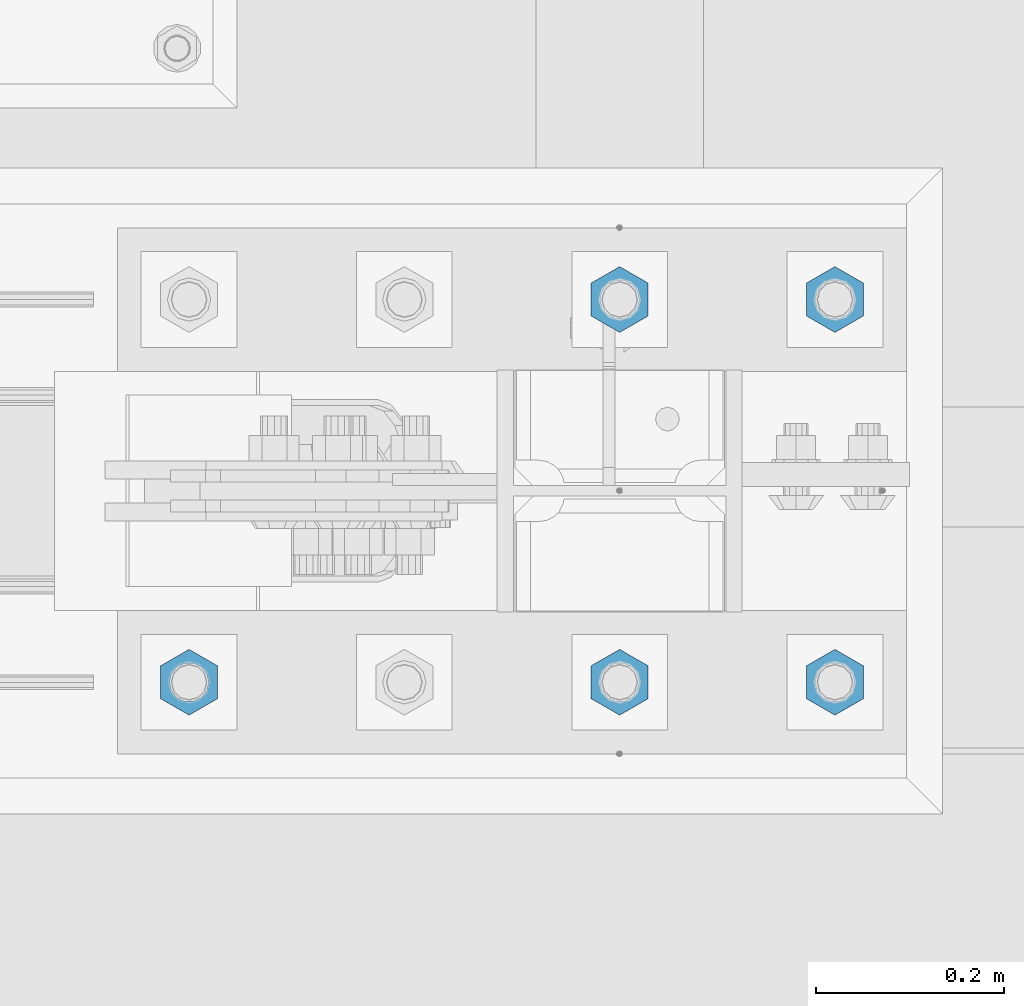
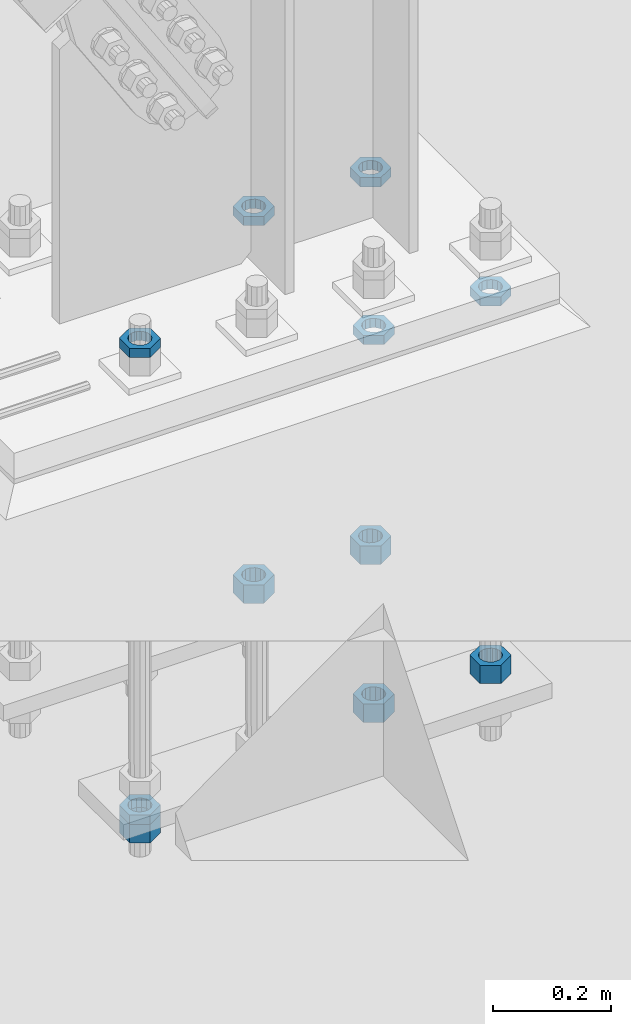
# One storey, part 2870 of 3843: 11 beams, 1 element without a shape of its own.
"""IFC2X3 building model written with IfcOpenShell, lengths in millimetres."""

from ifc_helpers import new_model, si_unit, frame, origin_with_axes, place, context, subcontext, project, spatial, faceted_brep, material, type_object, element, aggregate, save


model = new_model("IFC2X3")

# Units and contexts
model_context = context("Model", 3, precision=1e-05, world=origin_with_axes())
body_context = subcontext(model_context, "Body", "Model", "MODEL_VIEW")
ifc_project = project(units=[si_unit("LENGTHUNIT", "METRE", prefix="MILLI"), si_unit("AREAUNIT", "SQUARE_METRE"), si_unit("VOLUMEUNIT", "CUBIC_METRE"), si_unit("MASSUNIT", "GRAM", prefix="KILO"), si_unit("TIMEUNIT", "SECOND"), si_unit("PLANEANGLEUNIT", "RADIAN"), si_unit("SOLIDANGLEUNIT", "STERADIAN"), si_unit("THERMODYNAMICTEMPERATUREUNIT", "DEGREE_CELSIUS"), si_unit("LUMINOUSINTENSITYUNIT", "LUMEN")], contexts=[model_context])

# Site, building, storey
site_placement = place(None, origin_with_axes())
site = spatial("IfcSite", under=ifc_project, at=site_placement, CompositionType="ELEMENT")
building_placement = place(site_placement, origin_with_axes())
building = spatial("IfcBuilding", under=site, at=building_placement, Name="Undefined", CompositionType="ELEMENT")
storey_placement = place(building_placement, origin_with_axes())
storey = spatial("IfcBuildingStorey", under=building, at=storey_placement, Name="Undefined", CompositionType="ELEMENT", Elevation=0.0)

# Assembly, beams
assembly_placement = place(storey_placement, origin_with_axes())
assembly = element("IfcElementAssembly", 1, at=assembly_placement, inside=storey, Name="TEMPLATE", AssemblyPlace="NOTDEFINED", PredefinedType="RIGID_FRAME")
ifc_material = material(Name="STEEL/A572-50")
beam_type_1 = type_object("IfcBeamType", Name="1-1/2_HEAVY_HEX_NUT", PredefinedType="NOTDEFINED")
beam_1_placement = place(assembly_placement, frame((30708.6000195326, 88912.7, 29298.9), z_axis=(1.0, 0.0, 0.0), x_axis=(0.0, 0.0, -1.0)))
beam_1 = element("IfcBeam", 2, at=beam_1_placement, type_object=beam_type_1, material=ifc_material, Name="NUT", ObjectType="1-1/2_HEAVY_HEX_NUT", context=body_context, shape_type="Brep", body=[
    faceted_brep([(0.0, -34.9199981689453, 0.0), (0.0, -17.4599990844727, -30.25), (38.0999999999985, -17.4599990844727, -30.25), (38.0999999999985, -34.9199981689453, 0.0), (0.0, 17.4599990844727, -30.25), (38.0999999999985, 17.4599990844727, -30.25), (0.0, 34.9199981689453, 0.0), (38.0999999999985, 34.9199981689453, 0.0), (0.0, 17.4599990844727, 30.25), (38.0999999999985, 17.4599990844727, 30.25), (0.0, -17.4599990844727, 30.25), (38.0999999999985, -17.4599990844727, 30.25), (0.0, 0.0, 20.6399993896484), (0.0, 8.9553601105581, 18.5959968835959), (38.0999999999985, 8.9553601105581, 18.5959968835959), (38.0999999999985, 0.0, 20.6399993896484), (0.0, 16.1370013209525, 12.8688291298167), (38.0999999999985, 16.1370013209525, 12.8688291298167), (0.0, 20.1225115123816, 4.59283194104501), (38.0999999999985, 20.1225115123816, 4.59283194104501), (0.0, 20.1225115123816, -4.59283194104501), (38.0999999999985, 20.1225115123816, -4.59283194104501), (0.0, 16.1370013209525, -12.8688291298167), (38.0999999999985, 16.1370013209525, -12.8688291298167), (0.0, 8.9553601105581, -18.5959968835959), (38.0999999999985, 8.9553601105581, -18.5959968835959), (0.0, 0.0, -20.6399993896484), (38.0999999999985, 0.0, -20.6399993896484), (0.0, -8.9553601105581, -18.5959968835959), (38.0999999999985, -8.9553601105581, -18.5959968835959), (0.0, -16.1370013209525, -12.8688291298167), (38.0999999999985, -16.1370013209525, -12.8688291298167), (0.0, -20.1225115123816, -4.59283194104501), (38.0999999999985, -20.1225115123816, -4.59283194104501), (0.0, -20.1225115123816, 4.59283194104501), (38.0999999999985, -20.1225115123816, 4.59283194104501), (0.0, -16.1370013209525, 12.8688291298167), (38.0999999999985, -16.1370013209525, 12.8688291298167), (0.0, -8.9553601105581, 18.5959968835959), (38.0999999999985, -8.9553601105581, 18.5959968835959)], [[[0, 1, 2, 3]], [[1, 4, 5, 2]], [[4, 6, 7, 5]], [[6, 8, 9, 7]], [[8, 10, 11, 9]], [[10, 0, 3, 11]], [[12, 13, 14, 15]], [[13, 16, 17, 14]], [[16, 18, 19, 17]], [[18, 20, 21, 19]], [[20, 22, 23, 21]], [[22, 24, 25, 23]], [[24, 26, 27, 25]], [[26, 28, 29, 27]], [[28, 30, 31, 29]], [[30, 32, 33, 31]], [[32, 34, 35, 33]], [[34, 36, 37, 35]], [[36, 38, 39, 37]], [[38, 12, 15, 39]], [[5, 7, 9, 11, 3, 2], [17, 19, 21, 23, 25, 27, 29, 31, 33, 35, 37, 39, 15, 14]], [[10, 8, 6, 4, 1, 0], [38, 36, 34, 32, 30, 28, 26, 24, 22, 20, 18, 16, 13, 12]]]),
])
beam_2_placement = place(assembly_placement, frame((30480.0000195326, 88912.7, 29298.9), z_axis=(1.0, 0.0, 0.0), x_axis=(0.0, 0.0, -1.0)))
beam_2 = element("IfcBeam", 3, at=beam_2_placement, type_object=beam_type_1, material=ifc_material, Name="NUT", ObjectType="1-1/2_HEAVY_HEX_NUT", context=body_context, shape_type="Brep", body=[
    faceted_brep([(0.0, -34.9199981689453, 0.0), (0.0, -17.4599990844727, -30.25), (38.0999999999985, -17.4599990844727, -30.25), (38.0999999999985, -34.9199981689453, 0.0), (0.0, 17.4599990844727, -30.25), (38.0999999999985, 17.4599990844727, -30.25), (0.0, 34.9199981689453, 0.0), (38.0999999999985, 34.9199981689453, 0.0), (0.0, 17.4599990844727, 30.25), (38.0999999999985, 17.4599990844727, 30.25), (0.0, -17.4599990844727, 30.25), (38.0999999999985, -17.4599990844727, 30.25), (0.0, 0.0, 20.6399993896484), (0.0, 8.9553601105581, 18.5959968835959), (38.0999999999985, 8.9553601105581, 18.5959968835959), (38.0999999999985, 0.0, 20.6399993896484), (0.0, 16.1370013209525, 12.8688291298167), (38.0999999999985, 16.1370013209525, 12.8688291298167), (0.0, 20.1225115123816, 4.59283194104501), (38.0999999999985, 20.1225115123816, 4.59283194104501), (0.0, 20.1225115123816, -4.59283194104501), (38.0999999999985, 20.1225115123816, -4.59283194104501), (0.0, 16.1370013209525, -12.8688291298167), (38.0999999999985, 16.1370013209525, -12.8688291298167), (0.0, 8.9553601105581, -18.5959968835959), (38.0999999999985, 8.9553601105581, -18.5959968835959), (0.0, 0.0, -20.6399993896484), (38.0999999999985, 0.0, -20.6399993896484), (0.0, -8.9553601105581, -18.5959968835959), (38.0999999999985, -8.9553601105581, -18.5959968835959), (0.0, -16.1370013209525, -12.8688291298167), (38.0999999999985, -16.1370013209525, -12.8688291298167), (0.0, -20.1225115123816, -4.59283194104501), (38.0999999999985, -20.1225115123816, -4.59283194104501), (0.0, -20.1225115123816, 4.59283194104501), (38.0999999999985, -20.1225115123816, 4.59283194104501), (0.0, -16.1370013209525, 12.8688291298167), (38.0999999999985, -16.1370013209525, 12.8688291298167), (0.0, -8.9553601105581, 18.5959968835959), (38.0999999999985, -8.9553601105581, 18.5959968835959)], [[[0, 1, 2, 3]], [[1, 4, 5, 2]], [[4, 6, 7, 5]], [[6, 8, 9, 7]], [[8, 10, 11, 9]], [[10, 0, 3, 11]], [[12, 13, 14, 15]], [[13, 16, 17, 14]], [[16, 18, 19, 17]], [[18, 20, 21, 19]], [[20, 22, 23, 21]], [[22, 24, 25, 23]], [[24, 26, 27, 25]], [[26, 28, 29, 27]], [[28, 30, 31, 29]], [[30, 32, 33, 31]], [[32, 34, 35, 33]], [[34, 36, 37, 35]], [[36, 38, 39, 37]], [[38, 12, 15, 39]], [[5, 7, 9, 11, 3, 2], [17, 19, 21, 23, 25, 27, 29, 31, 33, 35, 37, 39, 15, 14]], [[10, 8, 6, 4, 1, 0], [38, 36, 34, 32, 30, 28, 26, 24, 22, 20, 18, 16, 13, 12]]]),
])
beam_3_placement = place(assembly_placement, frame((30708.5999804674, 89319.1, 29298.9), z_axis=(-1.0, 0.0, 0.0), x_axis=(0.0, 0.0, -1.0)))
beam_3 = element("IfcBeam", 4, at=beam_3_placement, type_object=beam_type_1, material=ifc_material, Name="NUT", ObjectType="1-1/2_HEAVY_HEX_NUT", context=body_context, shape_type="Brep", body=[
    faceted_brep([(0.0, -34.9199981689453, 0.0), (0.0, -17.4599990844727, -30.25), (38.0999999999985, -17.4599990844727, -30.25), (38.0999999999985, -34.9199981689453, 0.0), (0.0, 17.4599990844727, -30.25), (38.0999999999985, 17.4599990844727, -30.25), (0.0, 34.9199981689453, 0.0), (38.0999999999985, 34.9199981689453, 0.0), (0.0, 17.4599990844727, 30.25), (38.0999999999985, 17.4599990844727, 30.25), (0.0, -17.4599990844727, 30.25), (38.0999999999985, -17.4599990844727, 30.25), (0.0, 0.0, 20.6399993896484), (0.0, 8.9553601105581, 18.5959968835959), (38.0999999999985, 8.9553601105581, 18.5959968835959), (38.0999999999985, 0.0, 20.6399993896484), (0.0, 16.1370013209525, 12.8688291298167), (38.0999999999985, 16.1370013209525, 12.8688291298167), (0.0, 20.1225115123816, 4.59283194104501), (38.0999999999985, 20.1225115123816, 4.59283194104501), (0.0, 20.1225115123816, -4.59283194104501), (38.0999999999985, 20.1225115123816, -4.59283194104501), (0.0, 16.1370013209525, -12.8688291298167), (38.0999999999985, 16.1370013209525, -12.8688291298167), (0.0, 8.9553601105581, -18.5959968835959), (38.0999999999985, 8.9553601105581, -18.5959968835959), (0.0, 0.0, -20.6399993896484), (38.0999999999985, 0.0, -20.6399993896484), (0.0, -8.9553601105581, -18.5959968835959), (38.0999999999985, -8.9553601105581, -18.5959968835959), (0.0, -16.1370013209525, -12.8688291298167), (38.0999999999985, -16.1370013209525, -12.8688291298167), (0.0, -20.1225115123816, -4.59283194104501), (38.0999999999985, -20.1225115123816, -4.59283194104501), (0.0, -20.1225115123816, 4.59283194104501), (38.0999999999985, -20.1225115123816, 4.59283194104501), (0.0, -16.1370013209525, 12.8688291298167), (38.0999999999985, -16.1370013209525, 12.8688291298167), (0.0, -8.9553601105581, 18.5959968835959), (38.0999999999985, -8.9553601105581, 18.5959968835959)], [[[0, 1, 2, 3]], [[1, 4, 5, 2]], [[4, 6, 7, 5]], [[6, 8, 9, 7]], [[8, 10, 11, 9]], [[10, 0, 3, 11]], [[12, 13, 14, 15]], [[13, 16, 17, 14]], [[16, 18, 19, 17]], [[18, 20, 21, 19]], [[20, 22, 23, 21]], [[22, 24, 25, 23]], [[24, 26, 27, 25]], [[26, 28, 29, 27]], [[28, 30, 31, 29]], [[30, 32, 33, 31]], [[32, 34, 35, 33]], [[34, 36, 37, 35]], [[36, 38, 39, 37]], [[38, 12, 15, 39]], [[5, 7, 9, 11, 3, 2], [17, 19, 21, 23, 25, 27, 29, 31, 33, 35, 37, 39, 15, 14]], [[10, 8, 6, 4, 1, 0], [38, 36, 34, 32, 30, 28, 26, 24, 22, 20, 18, 16, 13, 12]]]),
])
beam_4_placement = place(assembly_placement, frame((30479.9999804674, 89319.1, 29298.9), z_axis=(-1.0, 0.0, 0.0), x_axis=(0.0, 0.0, -1.0)))
beam_4 = element("IfcBeam", 5, at=beam_4_placement, type_object=beam_type_1, material=ifc_material, Name="NUT", ObjectType="1-1/2_HEAVY_HEX_NUT", context=body_context, shape_type="Brep", body=[
    faceted_brep([(0.0, -34.9199981689453, 0.0), (0.0, -17.4599990844727, -30.25), (38.0999999999985, -17.4599990844727, -30.25), (38.0999999999985, -34.9199981689453, 0.0), (0.0, 17.4599990844727, -30.25), (38.0999999999985, 17.4599990844727, -30.25), (0.0, 34.9199981689453, 0.0), (38.0999999999985, 34.9199981689453, 0.0), (0.0, 17.4599990844727, 30.25), (38.0999999999985, 17.4599990844727, 30.25), (0.0, -17.4599990844727, 30.25), (38.0999999999985, -17.4599990844727, 30.25), (0.0, 0.0, 20.6399993896484), (0.0, 8.9553601105581, 18.5959968835959), (38.0999999999985, 8.9553601105581, 18.5959968835959), (38.0999999999985, 0.0, 20.6399993896484), (0.0, 16.1370013209525, 12.8688291298167), (38.0999999999985, 16.1370013209525, 12.8688291298167), (0.0, 20.1225115123816, 4.59283194104501), (38.0999999999985, 20.1225115123816, 4.59283194104501), (0.0, 20.1225115123816, -4.59283194104501), (38.0999999999985, 20.1225115123816, -4.59283194104501), (0.0, 16.1370013209525, -12.8688291298167), (38.0999999999985, 16.1370013209525, -12.8688291298167), (0.0, 8.9553601105581, -18.5959968835959), (38.0999999999985, 8.9553601105581, -18.5959968835959), (0.0, 0.0, -20.6399993896484), (38.0999999999985, 0.0, -20.6399993896484), (0.0, -8.9553601105581, -18.5959968835959), (38.0999999999985, -8.9553601105581, -18.5959968835959), (0.0, -16.1370013209525, -12.8688291298167), (38.0999999999985, -16.1370013209525, -12.8688291298167), (0.0, -20.1225115123816, -4.59283194104501), (38.0999999999985, -20.1225115123816, -4.59283194104501), (0.0, -20.1225115123816, 4.59283194104501), (38.0999999999985, -20.1225115123816, 4.59283194104501), (0.0, -16.1370013209525, 12.8688291298167), (38.0999999999985, -16.1370013209525, 12.8688291298167), (0.0, -8.9553601105581, 18.5959968835959), (38.0999999999985, -8.9553601105581, 18.5959968835959)], [[[0, 1, 2, 3]], [[1, 4, 5, 2]], [[4, 6, 7, 5]], [[6, 8, 9, 7]], [[8, 10, 11, 9]], [[10, 0, 3, 11]], [[12, 13, 14, 15]], [[13, 16, 17, 14]], [[16, 18, 19, 17]], [[18, 20, 21, 19]], [[20, 22, 23, 21]], [[22, 24, 25, 23]], [[24, 26, 27, 25]], [[26, 28, 29, 27]], [[28, 30, 31, 29]], [[30, 32, 33, 31]], [[32, 34, 35, 33]], [[34, 36, 37, 35]], [[36, 38, 39, 37]], [[38, 12, 15, 39]], [[5, 7, 9, 11, 3, 2], [17, 19, 21, 23, 25, 27, 29, 31, 33, 35, 37, 39, 15, 14]], [[10, 8, 6, 4, 1, 0], [38, 36, 34, 32, 30, 28, 26, 24, 22, 20, 18, 16, 13, 12]]]),
])
beam_5_placement = place(assembly_placement, frame((30022.8000195326, 88912.7, 29210.0), z_axis=(1.0, 0.0, 0.0), x_axis=(0.0, 0.0, -1.0)))
beam_5 = element("IfcBeam", 6, at=beam_5_placement, type_object=beam_type_1, material=ifc_material, Name="NUT", ObjectType="1-1/2_HEAVY_HEX_NUT", context=body_context, shape_type="Brep", body=[
    faceted_brep([(0.0, -34.9199981689453, 0.0), (0.0, -17.4599990844727, -30.25), (38.0999999999985, -17.4599990844727, -30.25), (38.0999999999985, -34.9199981689453, 0.0), (0.0, 17.4599990844727, -30.25), (38.0999999999985, 17.4599990844727, -30.25), (0.0, 34.9199981689453, 0.0), (38.0999999999985, 34.9199981689453, 0.0), (0.0, 17.4599990844727, 30.25), (38.0999999999985, 17.4599990844727, 30.25), (0.0, -17.4599990844727, 30.25), (38.0999999999985, -17.4599990844727, 30.25), (0.0, 0.0, 20.6399993896484), (0.0, 8.9553601105581, 18.5959968835959), (38.0999999999985, 8.9553601105581, 18.5959968835959), (38.0999999999985, 0.0, 20.6399993896484), (0.0, 16.1370013209525, 12.8688291298167), (38.0999999999985, 16.1370013209525, 12.8688291298167), (0.0, 20.1225115123816, 4.59283194104501), (38.0999999999985, 20.1225115123816, 4.59283194104501), (0.0, 20.1225115123816, -4.59283194104501), (38.0999999999985, 20.1225115123816, -4.59283194104501), (0.0, 16.1370013209525, -12.8688291298167), (38.0999999999985, 16.1370013209525, -12.8688291298167), (0.0, 8.9553601105581, -18.5959968835959), (38.0999999999985, 8.9553601105581, -18.5959968835959), (0.0, 0.0, -20.6399993896484), (38.0999999999985, 0.0, -20.6399993896484), (0.0, -8.9553601105581, -18.5959968835959), (38.0999999999985, -8.9553601105581, -18.5959968835959), (0.0, -16.1370013209525, -12.8688291298167), (38.0999999999985, -16.1370013209525, -12.8688291298167), (0.0, -20.1225115123816, -4.59283194104501), (38.0999999999985, -20.1225115123816, -4.59283194104501), (0.0, -20.1225115123816, 4.59283194104501), (38.0999999999985, -20.1225115123816, 4.59283194104501), (0.0, -16.1370013209525, 12.8688291298167), (38.0999999999985, -16.1370013209525, 12.8688291298167), (0.0, -8.9553601105581, 18.5959968835959), (38.0999999999985, -8.9553601105581, 18.5959968835959)], [[[0, 1, 2, 3]], [[1, 4, 5, 2]], [[4, 6, 7, 5]], [[6, 8, 9, 7]], [[8, 10, 11, 9]], [[10, 0, 3, 11]], [[12, 13, 14, 15]], [[13, 16, 17, 14]], [[16, 18, 19, 17]], [[18, 20, 21, 19]], [[20, 22, 23, 21]], [[22, 24, 25, 23]], [[24, 26, 27, 25]], [[26, 28, 29, 27]], [[28, 30, 31, 29]], [[30, 32, 33, 31]], [[32, 34, 35, 33]], [[34, 36, 37, 35]], [[36, 38, 39, 37]], [[38, 12, 15, 39]], [[5, 7, 9, 11, 3, 2], [17, 19, 21, 23, 25, 27, 29, 31, 33, 35, 37, 39, 15, 14]], [[10, 8, 6, 4, 1, 0], [38, 36, 34, 32, 30, 28, 26, 24, 22, 20, 18, 16, 13, 12]]]),
])
beam_type_2 = type_object("IfcBeamType", Name="1-1/2_HALF_NUT", PredefinedType="NOTDEFINED")
beam_6_placement = place(assembly_placement, frame((30708.6, 88912.7, 30060.9), z_axis=(1.0, 0.0, 0.0), x_axis=(0.0, 0.0, -1.0)))
beam_6 = element("IfcBeam", 7, at=beam_6_placement, type_object=beam_type_2, material=ifc_material, Name="NUT", ObjectType="1-1/2_HALF_NUT", context=body_context, shape_type="Brep", body=[
    faceted_brep([(0.0, -34.9199981689453, 0.0), (0.0, -17.4599990844727, -30.25), (19.0500000000029, -17.4599990844727, -30.25), (19.0500000000029, -34.9199981689453, 0.0), (0.0, 17.4599990844727, -30.25), (19.0500000000029, 17.4599990844727, -30.25), (0.0, 34.9199981689453, 0.0), (19.0500000000029, 34.9199981689453, 0.0), (0.0, 17.4599990844727, 30.25), (19.0500000000029, 17.4599990844727, 30.25), (0.0, -17.4599990844727, 30.25), (19.0500000000029, -17.4599990844727, 30.25), (0.0, 0.0, 20.6399993896484), (0.0, 8.9553601105581, 18.5959968835959), (19.0500000000029, 8.95536011056538, 18.5959968835959), (19.0500000000029, 0.0, 20.6399993896484), (0.0, 16.1370013209525, 12.8688291298167), (19.0500000000029, 16.1370013209489, 12.8688291298167), (0.0, 20.1225115123816, 4.59283194104501), (19.0500000000029, 20.1225115123852, 4.59283194104501), (0.0, 20.1225115123816, -4.59283194104501), (19.0500000000029, 20.1225115123852, -4.59283194104501), (0.0, 16.1370013209525, -12.8688291298167), (19.0500000000029, 16.1370013209489, -12.8688291298167), (0.0, 8.9553601105581, -18.5959968835959), (19.0500000000029, 8.95536011056538, -18.5959968835959), (0.0, 0.0, -20.6399993896484), (19.0500000000029, 0.0, -20.6399993896484), (0.0, -8.9553601105581, -18.5959968835959), (19.0500000000029, -8.95536011056538, -18.5959968835959), (0.0, -16.1370013209525, -12.8688291298167), (19.0500000000029, -16.1370013209489, -12.8688291298167), (0.0, -20.1225115123816, -4.59283194104501), (19.0500000000029, -20.1225115123852, -4.59283194104501), (0.0, -20.1225115123816, 4.59283194104501), (19.0500000000029, -20.1225115123852, 4.59283194104501), (0.0, -16.1370013209525, 12.8688291298167), (19.0500000000029, -16.1370013209489, 12.8688291298167), (0.0, -8.9553601105581, 18.5959968835959), (19.0500000000029, -8.95536011056538, 18.5959968835959)], [[[0, 1, 2, 3]], [[1, 4, 5, 2]], [[4, 6, 7, 5]], [[6, 8, 9, 7]], [[8, 10, 11, 9]], [[10, 0, 3, 11]], [[12, 13, 14, 15]], [[13, 16, 17, 14]], [[16, 18, 19, 17]], [[18, 20, 21, 19]], [[20, 22, 23, 21]], [[22, 24, 25, 23]], [[24, 26, 27, 25]], [[26, 28, 29, 27]], [[28, 30, 31, 29]], [[30, 32, 33, 31]], [[32, 34, 35, 33]], [[34, 36, 37, 35]], [[36, 38, 39, 37]], [[38, 12, 15, 39]], [[5, 7, 9, 11, 3, 2], [17, 19, 21, 23, 25, 27, 29, 31, 33, 35, 37, 39, 15, 14]], [[10, 8, 6, 4, 1, 0], [38, 36, 34, 32, 30, 28, 26, 24, 22, 20, 18, 16, 13, 12]]]),
])
beam_7_placement = place(assembly_placement, frame((30480.0, 88912.7, 30060.9), z_axis=(1.0, 0.0, 0.0), x_axis=(0.0, 0.0, -1.0)))
beam_7 = element("IfcBeam", 8, at=beam_7_placement, type_object=beam_type_2, material=ifc_material, Name="NUT", ObjectType="1-1/2_HALF_NUT", context=body_context, shape_type="Brep", body=[
    faceted_brep([(0.0, -34.9199981689453, 0.0), (0.0, -17.4599990844727, -30.25), (19.0500000000029, -17.4599990844727, -30.25), (19.0500000000029, -34.9199981689453, 0.0), (0.0, 17.4599990844727, -30.25), (19.0500000000029, 17.4599990844727, -30.25), (0.0, 34.9199981689453, 0.0), (19.0500000000029, 34.9199981689453, 0.0), (0.0, 17.4599990844727, 30.25), (19.0500000000029, 17.4599990844727, 30.25), (0.0, -17.4599990844727, 30.25), (19.0500000000029, -17.4599990844727, 30.25), (0.0, 0.0, 20.6399993896484), (0.0, 8.9553601105581, 18.5959968835959), (19.0500000000029, 8.95536011056538, 18.5959968835959), (19.0500000000029, 0.0, 20.6399993896484), (0.0, 16.1370013209525, 12.8688291298167), (19.0500000000029, 16.1370013209489, 12.8688291298167), (0.0, 20.1225115123816, 4.59283194104501), (19.0500000000029, 20.1225115123852, 4.59283194104501), (0.0, 20.1225115123816, -4.59283194104501), (19.0500000000029, 20.1225115123852, -4.59283194104501), (0.0, 16.1370013209525, -12.8688291298167), (19.0500000000029, 16.1370013209489, -12.8688291298167), (0.0, 8.9553601105581, -18.5959968835959), (19.0500000000029, 8.95536011056538, -18.5959968835959), (0.0, 0.0, -20.6399993896484), (19.0500000000029, 0.0, -20.6399993896484), (0.0, -8.9553601105581, -18.5959968835959), (19.0500000000029, -8.95536011056538, -18.5959968835959), (0.0, -16.1370013209525, -12.8688291298167), (19.0500000000029, -16.1370013209489, -12.8688291298167), (0.0, -20.1225115123816, -4.59283194104501), (19.0500000000029, -20.1225115123852, -4.59283194104501), (0.0, -20.1225115123816, 4.59283194104501), (19.0500000000029, -20.1225115123852, 4.59283194104501), (0.0, -16.1370013209525, 12.8688291298167), (19.0500000000029, -16.1370013209489, 12.8688291298167), (0.0, -8.9553601105581, 18.5959968835959), (19.0500000000029, -8.95536011056538, 18.5959968835959)], [[[0, 1, 2, 3]], [[1, 4, 5, 2]], [[4, 6, 7, 5]], [[6, 8, 9, 7]], [[8, 10, 11, 9]], [[10, 0, 3, 11]], [[12, 13, 14, 15]], [[13, 16, 17, 14]], [[16, 18, 19, 17]], [[18, 20, 21, 19]], [[20, 22, 23, 21]], [[22, 24, 25, 23]], [[24, 26, 27, 25]], [[26, 28, 29, 27]], [[28, 30, 31, 29]], [[30, 32, 33, 31]], [[32, 34, 35, 33]], [[34, 36, 37, 35]], [[36, 38, 39, 37]], [[38, 12, 15, 39]], [[5, 7, 9, 11, 3, 2], [17, 19, 21, 23, 25, 27, 29, 31, 33, 35, 37, 39, 15, 14]], [[10, 8, 6, 4, 1, 0], [38, 36, 34, 32, 30, 28, 26, 24, 22, 20, 18, 16, 13, 12]]]),
])
beam_8_placement = place(assembly_placement, frame((30708.5999511691, 89319.1, 30060.9), z_axis=(-1.0, 0.0, 0.0), x_axis=(0.0, 0.0, -1.0)))
beam_8 = element("IfcBeam", 9, at=beam_8_placement, type_object=beam_type_2, material=ifc_material, Name="NUT", ObjectType="1-1/2_HALF_NUT", context=body_context, shape_type="Brep", body=[
    faceted_brep([(0.0, -34.9199981689453, 0.0), (0.0, -17.4599990844727, -30.25), (19.0500000000029, -17.4599990844727, -30.25), (19.0500000000029, -34.9199981689453, 0.0), (0.0, 17.4599990844727, -30.25), (19.0500000000029, 17.4599990844727, -30.25), (0.0, 34.9199981689453, 0.0), (19.0500000000029, 34.9199981689453, 0.0), (0.0, 17.4599990844727, 30.25), (19.0500000000029, 17.4599990844727, 30.25), (0.0, -17.4599990844727, 30.25), (19.0500000000029, -17.4599990844727, 30.25), (0.0, 0.0, 20.6399993896484), (0.0, 8.9553601105581, 18.5959968835959), (19.0500000000029, 8.95536011056538, 18.5959968835959), (19.0500000000029, 0.0, 20.6399993896484), (0.0, 16.1370013209525, 12.8688291298167), (19.0500000000029, 16.1370013209489, 12.8688291298167), (0.0, 20.1225115123816, 4.59283194104501), (19.0500000000029, 20.1225115123852, 4.59283194104501), (0.0, 20.1225115123816, -4.59283194104501), (19.0500000000029, 20.1225115123852, -4.59283194104501), (0.0, 16.1370013209525, -12.8688291298167), (19.0500000000029, 16.1370013209489, -12.8688291298167), (0.0, 8.9553601105581, -18.5959968835959), (19.0500000000029, 8.95536011056538, -18.5959968835959), (0.0, 0.0, -20.6399993896484), (19.0500000000029, 0.0, -20.6399993896484), (0.0, -8.9553601105581, -18.5959968835959), (19.0500000000029, -8.95536011056538, -18.5959968835959), (0.0, -16.1370013209525, -12.8688291298167), (19.0500000000029, -16.1370013209489, -12.8688291298167), (0.0, -20.1225115123816, -4.59283194104501), (19.0500000000029, -20.1225115123852, -4.59283194104501), (0.0, -20.1225115123816, 4.59283194104501), (19.0500000000029, -20.1225115123852, 4.59283194104501), (0.0, -16.1370013209525, 12.8688291298167), (19.0500000000029, -16.1370013209489, 12.8688291298167), (0.0, -8.9553601105581, 18.5959968835959), (19.0500000000029, -8.95536011056538, 18.5959968835959)], [[[0, 1, 2, 3]], [[1, 4, 5, 2]], [[4, 6, 7, 5]], [[6, 8, 9, 7]], [[8, 10, 11, 9]], [[10, 0, 3, 11]], [[12, 13, 14, 15]], [[13, 16, 17, 14]], [[16, 18, 19, 17]], [[18, 20, 21, 19]], [[20, 22, 23, 21]], [[22, 24, 25, 23]], [[24, 26, 27, 25]], [[26, 28, 29, 27]], [[28, 30, 31, 29]], [[30, 32, 33, 31]], [[32, 34, 35, 33]], [[34, 36, 37, 35]], [[36, 38, 39, 37]], [[38, 12, 15, 39]], [[5, 7, 9, 11, 3, 2], [17, 19, 21, 23, 25, 27, 29, 31, 33, 35, 37, 39, 15, 14]], [[10, 8, 6, 4, 1, 0], [38, 36, 34, 32, 30, 28, 26, 24, 22, 20, 18, 16, 13, 12]]]),
])
beam_9_placement = place(assembly_placement, frame((30479.9999511691, 89319.1, 30060.9), z_axis=(-1.0, 0.0, 0.0), x_axis=(0.0, 0.0, -1.0)))
beam_9 = element("IfcBeam", 10, at=beam_9_placement, type_object=beam_type_2, material=ifc_material, Name="NUT", ObjectType="1-1/2_HALF_NUT", context=body_context, shape_type="Brep", body=[
    faceted_brep([(0.0, -34.9199981689453, 0.0), (0.0, -17.4599990844727, -30.25), (19.0500000000029, -17.4599990844727, -30.25), (19.0500000000029, -34.9199981689453, 0.0), (0.0, 17.4599990844727, -30.25), (19.0500000000029, 17.4599990844727, -30.25), (0.0, 34.9199981689453, 0.0), (19.0500000000029, 34.9199981689453, 0.0), (0.0, 17.4599990844727, 30.25), (19.0500000000029, 17.4599990844727, 30.25), (0.0, -17.4599990844727, 30.25), (19.0500000000029, -17.4599990844727, 30.25), (0.0, 0.0, 20.6399993896484), (0.0, 8.9553601105581, 18.5959968835959), (19.0500000000029, 8.95536011056538, 18.5959968835959), (19.0500000000029, 0.0, 20.6399993896484), (0.0, 16.1370013209525, 12.8688291298167), (19.0500000000029, 16.1370013209489, 12.8688291298167), (0.0, 20.1225115123816, 4.59283194104501), (19.0500000000029, 20.1225115123852, 4.59283194104501), (0.0, 20.1225115123816, -4.59283194104501), (19.0500000000029, 20.1225115123852, -4.59283194104501), (0.0, 16.1370013209525, -12.8688291298167), (19.0500000000029, 16.1370013209489, -12.8688291298167), (0.0, 8.9553601105581, -18.5959968835959), (19.0500000000029, 8.95536011056538, -18.5959968835959), (0.0, 0.0, -20.6399993896484), (19.0500000000029, 0.0, -20.6399993896484), (0.0, -8.9553601105581, -18.5959968835959), (19.0500000000029, -8.95536011056538, -18.5959968835959), (0.0, -16.1370013209525, -12.8688291298167), (19.0500000000029, -16.1370013209489, -12.8688291298167), (0.0, -20.1225115123816, -4.59283194104501), (19.0500000000029, -20.1225115123852, -4.59283194104501), (0.0, -20.1225115123816, 4.59283194104501), (19.0500000000029, -20.1225115123852, 4.59283194104501), (0.0, -16.1370013209525, 12.8688291298167), (19.0500000000029, -16.1370013209489, 12.8688291298167), (0.0, -8.9553601105581, 18.5959968835959), (19.0500000000029, -8.95536011056538, 18.5959968835959)], [[[0, 1, 2, 3]], [[1, 4, 5, 2]], [[4, 6, 7, 5]], [[6, 8, 9, 7]], [[8, 10, 11, 9]], [[10, 0, 3, 11]], [[12, 13, 14, 15]], [[13, 16, 17, 14]], [[16, 18, 19, 17]], [[18, 20, 21, 19]], [[20, 22, 23, 21]], [[22, 24, 25, 23]], [[24, 26, 27, 25]], [[26, 28, 29, 27]], [[28, 30, 31, 29]], [[30, 32, 33, 31]], [[32, 34, 35, 33]], [[34, 36, 37, 35]], [[36, 38, 39, 37]], [[38, 12, 15, 39]], [[5, 7, 9, 11, 3, 2], [17, 19, 21, 23, 25, 27, 29, 31, 33, 35, 37, 39, 15, 14]], [[10, 8, 6, 4, 1, 0], [38, 36, 34, 32, 30, 28, 26, 24, 22, 20, 18, 16, 13, 12]]]),
])
beam_10_placement = place(assembly_placement, frame((30022.8000244154, 88912.7, 30194.25), z_axis=(1.0, 0.0, 0.0), x_axis=(0.0, 0.0, -1.0)))
beam_10 = element("IfcBeam", 11, at=beam_10_placement, type_object=beam_type_2, material=ifc_material, Name="NUT", ObjectType="1-1/2_HALF_NUT", context=body_context, shape_type="Brep", body=[
    faceted_brep([(0.0, -34.9199981689453, 0.0), (0.0, -17.4599990844727, -30.25), (19.0500000000029, -17.4599990844727, -30.25), (19.0500000000029, -34.9199981689453, 0.0), (0.0, 17.4599990844727, -30.25), (19.0500000000029, 17.4599990844727, -30.25), (0.0, 34.9199981689453, 0.0), (19.0500000000029, 34.9199981689453, 0.0), (0.0, 17.4599990844727, 30.25), (19.0500000000029, 17.4599990844727, 30.25), (0.0, -17.4599990844727, 30.25), (19.0500000000029, -17.4599990844727, 30.25), (0.0, 0.0, 20.6399993896484), (0.0, 8.9553601105581, 18.5959968835959), (19.0500000000029, 8.95536011056538, 18.5959968835959), (19.0500000000029, 0.0, 20.6399993896484), (0.0, 16.1370013209525, 12.8688291298167), (19.0500000000029, 16.1370013209489, 12.8688291298167), (0.0, 20.1225115123816, 4.59283194104501), (19.0500000000029, 20.1225115123852, 4.59283194104501), (0.0, 20.1225115123816, -4.59283194104501), (19.0500000000029, 20.1225115123852, -4.59283194104501), (0.0, 16.1370013209525, -12.8688291298167), (19.0500000000029, 16.1370013209489, -12.8688291298167), (0.0, 8.9553601105581, -18.5959968835959), (19.0500000000029, 8.95536011056538, -18.5959968835959), (0.0, 0.0, -20.6399993896484), (19.0500000000029, 0.0, -20.6399993896484), (0.0, -8.9553601105581, -18.5959968835959), (19.0500000000029, -8.95536011056538, -18.5959968835959), (0.0, -16.1370013209525, -12.8688291298167), (19.0500000000029, -16.1370013209489, -12.8688291298167), (0.0, -20.1225115123816, -4.59283194104501), (19.0500000000029, -20.1225115123852, -4.59283194104501), (0.0, -20.1225115123816, 4.59283194104501), (19.0500000000029, -20.1225115123852, 4.59283194104501), (0.0, -16.1370013209525, 12.8688291298167), (19.0500000000029, -16.1370013209489, 12.8688291298167), (0.0, -8.9553601105581, 18.5959968835959), (19.0500000000029, -8.95536011056538, 18.5959968835959)], [[[0, 1, 2, 3]], [[1, 4, 5, 2]], [[4, 6, 7, 5]], [[6, 8, 9, 7]], [[8, 10, 11, 9]], [[10, 0, 3, 11]], [[12, 13, 14, 15]], [[13, 16, 17, 14]], [[16, 18, 19, 17]], [[18, 20, 21, 19]], [[20, 22, 23, 21]], [[22, 24, 25, 23]], [[24, 26, 27, 25]], [[26, 28, 29, 27]], [[28, 30, 31, 29]], [[30, 32, 33, 31]], [[32, 34, 35, 33]], [[34, 36, 37, 35]], [[36, 38, 39, 37]], [[38, 12, 15, 39]], [[5, 7, 9, 11, 3, 2], [17, 19, 21, 23, 25, 27, 29, 31, 33, 35, 37, 39, 15, 14]], [[10, 8, 6, 4, 1, 0], [38, 36, 34, 32, 30, 28, 26, 24, 22, 20, 18, 16, 13, 12]]]),
])
beam_11_placement = place(assembly_placement, frame((30022.8, 88912.7, 29229.05), z_axis=(1.0, 0.0, 0.0), x_axis=(0.0, 0.0, -1.0)))
beam_11 = element("IfcBeam", 12, at=beam_11_placement, type_object=beam_type_2, material=ifc_material, Name="NUT", ObjectType="1-1/2_HALF_NUT", context=body_context, shape_type="Brep", body=[
    faceted_brep([(0.0, -34.9199981689453, 0.0), (0.0, -17.4599990844727, -30.25), (19.0500000000029, -17.4599990844727, -30.25), (19.0500000000029, -34.9199981689453, 0.0), (0.0, 17.4599990844727, -30.25), (19.0500000000029, 17.4599990844727, -30.25), (0.0, 34.9199981689453, 0.0), (19.0500000000029, 34.9199981689453, 0.0), (0.0, 17.4599990844727, 30.25), (19.0500000000029, 17.4599990844727, 30.25), (0.0, -17.4599990844727, 30.25), (19.0500000000029, -17.4599990844727, 30.25), (0.0, 0.0, 20.6399993896484), (0.0, 8.9553601105581, 18.5959968835959), (19.0500000000029, 8.95536011056538, 18.5959968835959), (19.0500000000029, 0.0, 20.6399993896484), (0.0, 16.1370013209525, 12.8688291298167), (19.0500000000029, 16.1370013209489, 12.8688291298167), (0.0, 20.1225115123816, 4.59283194104501), (19.0500000000029, 20.1225115123852, 4.59283194104501), (0.0, 20.1225115123816, -4.59283194104501), (19.0500000000029, 20.1225115123852, -4.59283194104501), (0.0, 16.1370013209525, -12.8688291298167), (19.0500000000029, 16.1370013209489, -12.8688291298167), (0.0, 8.9553601105581, -18.5959968835959), (19.0500000000029, 8.95536011056538, -18.5959968835959), (0.0, 0.0, -20.6399993896484), (19.0500000000029, 0.0, -20.6399993896484), (0.0, -8.9553601105581, -18.5959968835959), (19.0500000000029, -8.95536011056538, -18.5959968835959), (0.0, -16.1370013209525, -12.8688291298167), (19.0500000000029, -16.1370013209489, -12.8688291298167), (0.0, -20.1225115123816, -4.59283194104501), (19.0500000000029, -20.1225115123852, -4.59283194104501), (0.0, -20.1225115123816, 4.59283194104501), (19.0500000000029, -20.1225115123852, 4.59283194104501), (0.0, -16.1370013209525, 12.8688291298167), (19.0500000000029, -16.1370013209489, 12.8688291298167), (0.0, -8.9553601105581, 18.5959968835959), (19.0500000000029, -8.95536011056538, 18.5959968835959)], [[[0, 1, 2, 3]], [[1, 4, 5, 2]], [[4, 6, 7, 5]], [[6, 8, 9, 7]], [[8, 10, 11, 9]], [[10, 0, 3, 11]], [[12, 13, 14, 15]], [[13, 16, 17, 14]], [[16, 18, 19, 17]], [[18, 20, 21, 19]], [[20, 22, 23, 21]], [[22, 24, 25, 23]], [[24, 26, 27, 25]], [[26, 28, 29, 27]], [[28, 30, 31, 29]], [[30, 32, 33, 31]], [[32, 34, 35, 33]], [[34, 36, 37, 35]], [[36, 38, 39, 37]], [[38, 12, 15, 39]], [[5, 7, 9, 11, 3, 2], [17, 19, 21, 23, 25, 27, 29, 31, 33, 35, 37, 39, 15, 14]], [[10, 8, 6, 4, 1, 0], [38, 36, 34, 32, 30, 28, 26, 24, 22, 20, 18, 16, 13, 12]]]),
])
aggregate(assembly, [beam_1, beam_2, beam_3, beam_4, beam_6, beam_7, beam_8, beam_9, beam_5, beam_10, beam_11])

save(model, "model.ifc")
